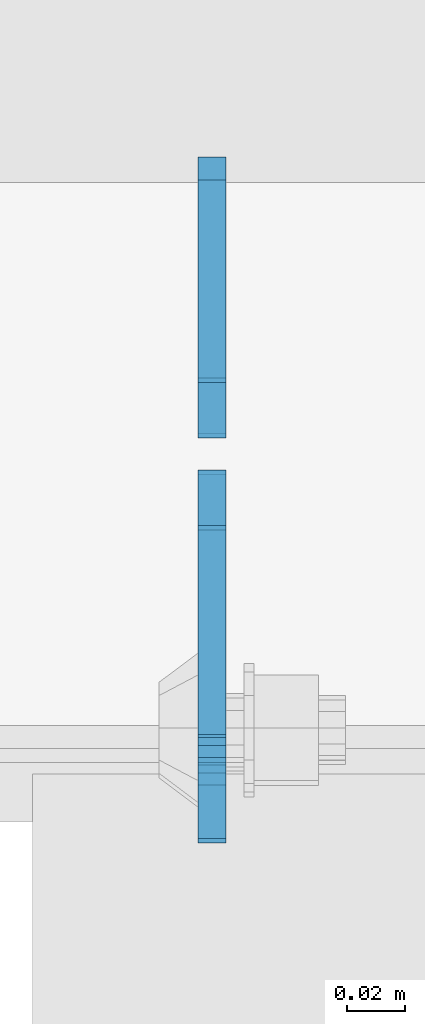
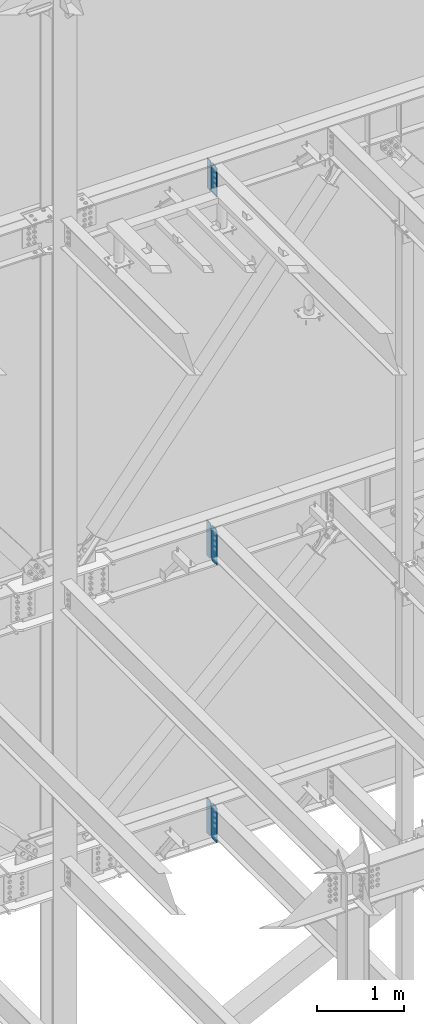
# One storey, part 1075 of 1179: 6 plates, 3 elements without a shape of their own.
"""IFC2X3 building model written with IfcOpenShell, lengths in millimetres."""

from ifc_helpers import new_model, si_unit, frame, origin_with_axes, place, context, subcontext, project, spatial, faceted_brep, material, type_object, element, aggregate, save


model = new_model("IFC2X3")

# Units and contexts
model_context = context("Model", 3, precision=1e-05, world=origin_with_axes())
body_context = subcontext(model_context, "Body", "Model", "MODEL_VIEW")
ifc_project = project(units=[si_unit("LENGTHUNIT", "METRE", prefix="MILLI"), si_unit("AREAUNIT", "SQUARE_METRE"), si_unit("VOLUMEUNIT", "CUBIC_METRE"), si_unit("MASSUNIT", "GRAM", prefix="KILO"), si_unit("TIMEUNIT", "SECOND"), si_unit("PLANEANGLEUNIT", "RADIAN"), si_unit("SOLIDANGLEUNIT", "STERADIAN"), si_unit("THERMODYNAMICTEMPERATUREUNIT", "DEGREE_CELSIUS"), si_unit("LUMINOUSINTENSITYUNIT", "LUMEN")], contexts=[model_context])

# Site, building, storey
site_placement = place(None, origin_with_axes())
site = spatial("IfcSite", under=ifc_project, at=site_placement, CompositionType="ELEMENT")
building_placement = place(site_placement, origin_with_axes())
building = spatial("IfcBuilding", under=site, at=building_placement, Name="Undefined", CompositionType="ELEMENT")
storey_placement = place(building_placement, origin_with_axes())
storey = spatial("IfcBuildingStorey", under=building, at=storey_placement, Name="Undefined", CompositionType="ELEMENT", Elevation=0.0)

# Assembly, plate
assembly_1_placement = place(storey_placement, origin_with_axes())
assembly_1 = element("IfcElementAssembly", 1, at=assembly_1_placement, inside=storey, Name="BEAM", AssemblyPlace="NOTDEFINED", PredefinedType="RIGID_FRAME")
ifc_material = material(Name="STEEL/A36")
plate_type_1 = type_object("IfcPlateType", PredefinedType="NOTDEFINED")
plate_1_placement = place(assembly_1_placement, frame((10317.1620000839, 41193.24375, 12673.0125), z_axis=(0.0, 0.0, 1.0), x_axis=(0.0, -1.0, 0.0)))
plate_1 = element("IfcPlate", 2, at=plate_1_placement, type_object=plate_type_1, material=ifc_material, Name="PLATE", context=body_context, shape_type="Brep", body=[
    faceted_brep([(91.28125, -4.76250000000073, 425.450000000001), (91.28125, -4.76250000000073, 420.687499809264), (91.28125, 4.76250000000073, 420.687499809264), (91.28125, 4.76250000000073, 425.450000000001), (92.2479799225912, -4.76250000000073, 415.827420291219), (92.2479799225912, 4.76250000000073, 415.827420291219), (95.0009938230651, -4.76250000000073, 411.707243823065), (95.0009938230651, 4.76250000000073, 411.707243823065), (99.1211702912187, -4.76250000000073, 408.954229922587), (99.1211702912187, 4.76250000000073, 408.954229922587), (103.981249809265, -4.76250000000073, 407.987499999999), (103.981249809265, 4.76250000000073, 407.987499999999), (126.999999992826, -4.76249999999709, 407.9875), (127.0, 4.76249999999709, 407.9875), (0.0, -4.76249999999709, 406.400000762939), (19.0499992370605, -4.76249999999709, 425.45), (19.0499992370605, 4.76249999999709, 425.45), (0.0, 4.76249999999709, 406.400000762939), (0.0, -4.76250000000073, 19.0499992370605), (0.0, 4.76250000000073, 19.0499992370605), (19.0499992370605, -4.76250000000073, 0.0), (19.0499992370605, 4.76250000000073, 0.0), (127.0, -4.76250000000073, 0.0), (127.0, 4.76250000000073, 0.0)], [[[0, 1, 2, 3]], [[4, 5, 2, 1]], [[6, 7, 5, 4]], [[8, 9, 7, 6]], [[10, 11, 9, 8]], [[12, 13, 11, 10]], [[14, 15, 16, 17]], [[18, 14, 17, 19]], [[20, 18, 19, 21]], [[22, 20, 21, 23]], [[8, 6, 4, 1, 0, 15, 14, 18, 20, 22, 12, 10]], [[16, 15, 0, 3]], [[23, 21, 19, 17, 16, 3, 2, 5, 7, 9, 11, 13]], [[22, 23, 13, 12]]]),
])

assembly_2_placement = place(storey_placement, origin_with_axes())
assembly_2 = element("IfcElementAssembly", 3, at=assembly_2_placement, inside=storey, Name="BEAM", AssemblyPlace="NOTDEFINED", PredefinedType="RIGID_FRAME")
plate_2_placement = place(assembly_2_placement, frame((10317.1620000839, 41191.65625, 7489.825), z_axis=(0.0, 0.0, 1.0), x_axis=(0.0, -1.0, 0.0)))
plate_2 = element("IfcPlate", 4, at=plate_2_placement, type_object=plate_type_1, material=ifc_material, Name="PLATE", context=body_context, shape_type="Brep", body=[
    faceted_brep([(99.2187497618652, -4.76249999998072, 498.475), (99.21875, -4.76250000000073, 492.124999809264), (99.21875, 4.76250000000073, 492.124999809264), (99.2187499999927, 4.76250000001892, 498.475), (100.185479922588, -4.76250000000073, 487.264920291219), (100.185479922588, 4.76250000000073, 487.264920291219), (102.938493823065, -4.76250000000073, 483.144743823065), (102.938493823065, 4.76250000000073, 483.144743823065), (107.058670291219, -4.76250000000073, 480.391729922587), (107.058670291219, 4.76250000000073, 480.391729922587), (111.918749809265, -4.76250000000073, 479.424999999999), (111.918749809265, 4.76250000000073, 479.424999999999), (127.000007629395, -4.76250000000073, 479.424999999999), (127.000004683803, 4.76250000000073, 479.424999999999), (0.0, -4.76250000000073, 479.425006866455), (19.0499992370605, -4.76250000000073, 498.475006103516), (19.0499992370605, 4.76250000000073, 498.475006103516), (0.0, 4.76250000000073, 479.425006866455), (0.0, -4.76250000000073, 19.0499992370605), (0.0, 4.76250000000073, 19.0499992370605), (19.0499992370605, -4.76250000000073, 0.0), (19.0499992370605, 4.76250000000073, 0.0), (127.0, -4.76250000000073, 0.0), (127.0, 4.76250000000073, 0.0)], [[[0, 1, 2, 3]], [[4, 5, 2, 1]], [[6, 7, 5, 4]], [[8, 9, 7, 6]], [[10, 11, 9, 8]], [[12, 13, 11, 10]], [[14, 15, 16, 17]], [[18, 14, 17, 19]], [[20, 18, 19, 21]], [[22, 20, 21, 23]], [[8, 6, 4, 1, 0, 15, 14, 18, 20, 22, 12, 10]], [[16, 15, 0, 3]], [[23, 21, 19, 17, 16, 3, 2, 5, 7, 9, 11, 13]], [[22, 23, 13, 12]]]),
])

assembly_3_placement = place(storey_placement, origin_with_axes())
assembly_3 = element("IfcElementAssembly", 5, at=assembly_3_placement, inside=storey, Name="BEAM", AssemblyPlace="NOTDEFINED", PredefinedType="RIGID_FRAME")
plate_3_placement = place(assembly_3_placement, frame((10317.1620836029, 41191.6562498809, 3578.225), z_axis=(0.0, 0.0, 1.0), x_axis=(0.0, -1.0, 0.0)))
plate_3 = element("IfcPlate", 6, at=plate_3_placement, type_object=plate_type_1, material=ifc_material, Name="PLATE", context=body_context, shape_type="Brep", body=[
    faceted_brep([(100.185729626639, -4.76249977056068, 493.614920291231), (100.185729712364, 4.76250000001892, 493.614920291231), (99.2189997897731, 4.76250000002074, 498.475), (99.218999704055, -4.76249999998072, 498.475), (102.93874352712, -4.76249979533713, 489.494743823075), (102.938743612845, 4.76250000002074, 489.494743823075), (107.058919995281, -4.76249983241905, 486.741729922598), (107.058920081006, 4.76250000002074, 486.741729922598), (111.918999513335, -4.76249987616211, 485.775000000015), (111.918999599053, 4.76250000002074, 485.775000000015), (127.000004753965, -4.76249999997526, 485.775), (127.000004873044, 4.76250000002437, 485.775), (0.0, -4.76250000000073, 479.425006866455), (19.0499992370605, -4.76250000000073, 498.475006103516), (19.0499992370605, 4.76250000000073, 498.475006103516), (0.0, 4.76250000000073, 479.425006866455), (0.0, -4.76250000000073, 19.0499992370605), (0.0, 4.76250000000073, 19.0499992370605), (19.0499992370605, -4.76250000000073, 0.0), (19.0499992370605, 4.76250000000073, 0.0), (127.0, -4.76250000000073, 0.0), (127.0, 4.76250000000073, 0.0)], [[[0, 1, 2, 3]], [[4, 5, 1, 0]], [[6, 7, 5, 4]], [[8, 9, 7, 6]], [[10, 11, 9, 8]], [[12, 13, 14, 15]], [[16, 12, 15, 17]], [[18, 16, 17, 19]], [[20, 18, 19, 21]], [[6, 4, 0, 3, 13, 12, 16, 18, 20, 10, 8]], [[14, 13, 3, 2]], [[21, 19, 17, 15, 14, 2, 1, 5, 7, 9, 11]], [[20, 21, 11, 10]]]),
])

# Plate
plate_type_2 = type_object("IfcPlateType", PredefinedType="NOTDEFINED")
plate_4_placement = place(assembly_1_placement, frame((10317.1620000839, 41204.35625, 12673.0125), z_axis=(0.0, 0.0, 1.0), x_axis=(0.0, 1.0, 0.0)))
plate_4 = element("IfcPlate", 7, at=plate_4_placement, type_object=plate_type_2, material=ifc_material, Name="PLATE", context=body_context, shape_type="Brep", body=[
    faceted_brep([(0.0, -4.76250000000073, 19.0499992370605), (0.0, -4.76249999999709, 406.400000762939), (0.0, 4.76249999999709, 406.400000762939), (0.0, 4.76250000000073, 19.0499992370605), (19.0499992370605, -4.76249999999709, 425.45), (19.0499992370605, 4.76249999999709, 425.45), (88.9000015258789, -4.76250000000073, 425.450012207031), (88.9000015258789, 4.76250000000073, 425.450012207031), (88.8999999999996, -4.76250000000005, 0.0), (88.8999999999996, 4.76250000000005, 0.0), (19.0499992370605, -4.76250000000073, 0.0), (19.0499992370605, 4.76250000000073, 0.0)], [[[0, 1, 2, 3]], [[1, 4, 5, 2]], [[4, 6, 7, 5]], [[6, 8, 9, 7]], [[8, 10, 11, 9]], [[10, 0, 3, 11]], [[5, 7, 9, 11, 3, 2]], [[10, 8, 6, 4, 1, 0]]]),
])

aggregate(assembly_1, [plate_4, plate_1])

plate_type_3 = type_object("IfcPlateType", PredefinedType="NOTDEFINED")
plate_5_placement = place(assembly_2_placement, frame((10317.1620000839, 41205.94375, 7489.825), z_axis=(0.0, 0.0, 1.0), x_axis=(0.0, 1.0, 0.0)))
plate_5 = element("IfcPlate", 8, at=plate_5_placement, type_object=plate_type_3, material=ifc_material, Name="PLATE", context=body_context, shape_type="Brep", body=[
    faceted_brep([(0.0, -4.76250000000073, 19.0499992370605), (0.0, -4.76250000000073, 479.425006866455), (0.0, 4.76250000000073, 479.425006866455), (0.0, 4.76250000000073, 19.0499992370605), (19.0499992370605, -4.76250000000073, 498.475006103516), (19.0499992370605, 4.76250000000073, 498.475006103516), (95.25, -4.76250000000073, 498.475006103516), (95.25, 4.76250000000073, 498.475006103516), (95.25, -4.76250000000073, 0.0), (95.25, 4.76250000000073, 0.0), (19.0499992370605, -4.76250000000073, 0.0), (19.0499992370605, 4.76250000000073, 0.0)], [[[0, 1, 2, 3]], [[1, 4, 5, 2]], [[4, 6, 7, 5]], [[6, 8, 9, 7]], [[8, 10, 11, 9]], [[10, 0, 3, 11]], [[5, 7, 9, 11, 3, 2]], [[10, 8, 6, 4, 1, 0]]]),
])

aggregate(assembly_2, [plate_5, plate_2])

plate_6_placement = place(assembly_3_placement, frame((10317.1620835822, 41205.94375, 3578.225), z_axis=(0.0, 0.0, 1.0), x_axis=(0.0, 1.0, 0.0)))
plate_6 = element("IfcPlate", 9, at=plate_6_placement, type_object=plate_type_3, material=ifc_material, Name="PLATE", context=body_context, shape_type="Brep", body=[
    faceted_brep([(0.0, -4.76250000000073, 19.0499992370605), (0.0, -4.76250000000073, 479.425006866455), (0.0, 4.76250000000073, 479.425006866455), (0.0, 4.76250000000073, 19.0499992370605), (19.0499992370605, -4.76250000000073, 498.475006103516), (19.0499992370605, 4.76250000000073, 498.475006103516), (95.25, -4.76250000000073, 498.475006103516), (95.25, 4.76250000000073, 498.475006103516), (95.25, -4.76250000000073, 0.0), (95.25, 4.76250000000073, 0.0), (19.0499992370605, -4.76250000000073, 0.0), (19.0499992370605, 4.76250000000073, 0.0)], [[[0, 1, 2, 3]], [[1, 4, 5, 2]], [[4, 6, 7, 5]], [[6, 8, 9, 7]], [[8, 10, 11, 9]], [[10, 0, 3, 11]], [[5, 7, 9, 11, 3, 2]], [[10, 8, 6, 4, 1, 0]]]),
])

aggregate(assembly_3, [plate_6, plate_3])

save(model, "model.ifc")
